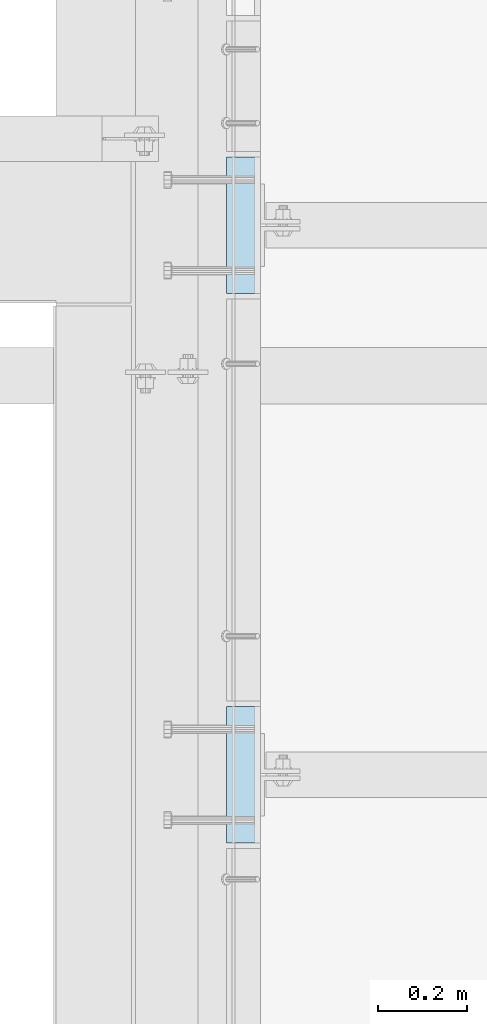
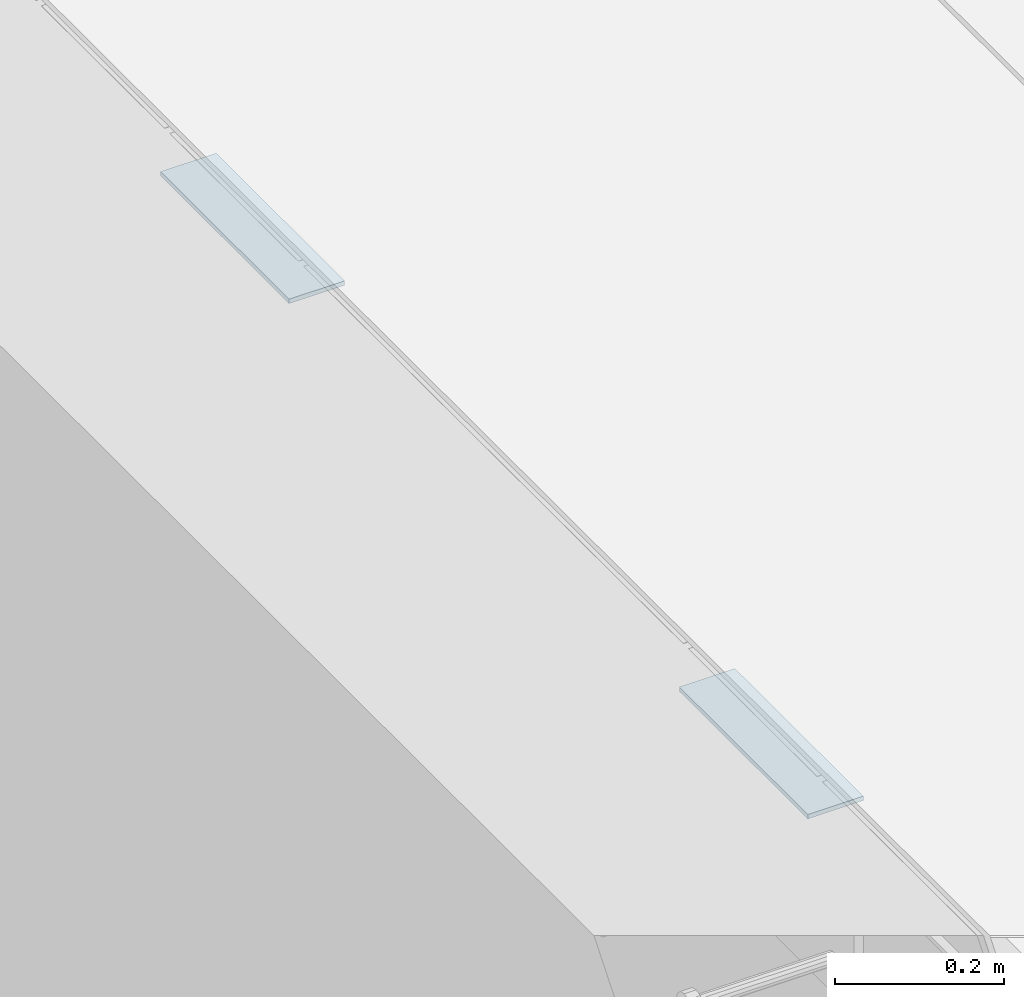
# One storey, part 3111 of 3843: 2 plates, 2 elements without a shape of their own.
"""IFC2X3 building model written with IfcOpenShell, lengths in millimetres."""

from ifc_helpers import new_model, si_unit, frame, origin_with_axes, place, context, subcontext, project, spatial, faceted_brep, material, type_object, element, aggregate, save


model = new_model("IFC2X3")

# Units and contexts
model_context = context("Model", 3, precision=1e-05, world=origin_with_axes())
body_context = subcontext(model_context, "Body", "Model", "MODEL_VIEW")
ifc_project = project(units=[si_unit("LENGTHUNIT", "METRE", prefix="MILLI"), si_unit("AREAUNIT", "SQUARE_METRE"), si_unit("VOLUMEUNIT", "CUBIC_METRE"), si_unit("MASSUNIT", "GRAM", prefix="KILO"), si_unit("TIMEUNIT", "SECOND"), si_unit("PLANEANGLEUNIT", "RADIAN"), si_unit("SOLIDANGLEUNIT", "STERADIAN"), si_unit("THERMODYNAMICTEMPERATUREUNIT", "DEGREE_CELSIUS"), si_unit("LUMINOUSINTENSITYUNIT", "LUMEN")], contexts=[model_context])

# Site, building, storey
site_placement = place(None, origin_with_axes())
site = spatial("IfcSite", under=ifc_project, at=site_placement, CompositionType="ELEMENT")
building_placement = place(site_placement, origin_with_axes())
building = spatial("IfcBuilding", under=site, at=building_placement, Name="Undefined", CompositionType="ELEMENT")
storey_placement = place(building_placement, origin_with_axes())
storey = spatial("IfcBuildingStorey", under=building, at=storey_placement, Name="Undefined", CompositionType="ELEMENT", Elevation=0.0)

# Assembly, plate
assembly_1_placement = place(storey_placement, origin_with_axes())
assembly_1 = element("IfcElementAssembly", 1, at=assembly_1_placement, inside=storey, Name="EMBED PLATE", AssemblyPlace="NOTDEFINED", PredefinedType="RIGID_FRAME")
ifc_material = material(Name="STEEL/A36")
plate_type = type_object("IfcPlateType", PredefinedType="NOTDEFINED")
plate_1_placement = place(assembly_1_placement, frame((56140.3500030518, 17611.725, 30426.025), z_axis=(0.0, -1.0, 0.0), x_axis=(-1.0, 0.0, 0.0)))
plate_1 = element("IfcPlate", 2, at=plate_1_placement, type_object=plate_type, material=ifc_material, Name="PLATE", context=body_context, shape_type="Brep", body=[
    faceted_brep([(0.0, -3.17499999999927, 0.0), (0.0, -3.17499999999927, 304.800000000003), (0.0, 3.17499999999927, 304.800000000003), (0.0, 3.17499999999927, 0.0), (76.1999999999971, -3.17499999999927, 304.799999999996), (76.1999999999971, 3.17499999999927, 304.799999999996), (76.1999999999971, -3.17499999999927, 0.0), (76.1999999999971, 3.17499999999927, 0.0)], [[[0, 1, 2, 3]], [[1, 4, 5, 2]], [[4, 6, 7, 5]], [[6, 0, 3, 7]], [[5, 7, 3, 2]], [[6, 4, 1, 0]]]),
])
aggregate(assembly_1, [plate_1])

assembly_2_placement = place(storey_placement, origin_with_axes())
assembly_2 = element("IfcElementAssembly", 3, at=assembly_2_placement, inside=storey, Name="EMBED PLATE", AssemblyPlace="NOTDEFINED", PredefinedType="RIGID_FRAME")
plate_2_placement = place(assembly_2_placement, frame((56140.3500030517, 16381.4125, 30426.025), z_axis=(0.0, -1.0, 0.0), x_axis=(-1.0, 0.0, 0.0)))
plate_2 = element("IfcPlate", 4, at=plate_2_placement, type_object=plate_type, material=ifc_material, Name="PLATE", context=body_context, shape_type="Brep", body=[
    faceted_brep([(0.0, -3.17499999999927, 0.0), (0.0, -3.17499999999927, 304.800000000003), (0.0, 3.17499999999927, 304.800000000003), (0.0, 3.17499999999927, 0.0), (76.1999999999971, -3.17499999999927, 304.799999999996), (76.1999999999971, 3.17499999999927, 304.799999999996), (76.1999999999971, -3.17499999999927, 0.0), (76.1999999999971, 3.17499999999927, 0.0)], [[[0, 1, 2, 3]], [[1, 4, 5, 2]], [[4, 6, 7, 5]], [[6, 0, 3, 7]], [[5, 7, 3, 2]], [[6, 4, 1, 0]]]),
])
aggregate(assembly_2, [plate_2])

save(model, "model.ifc")
